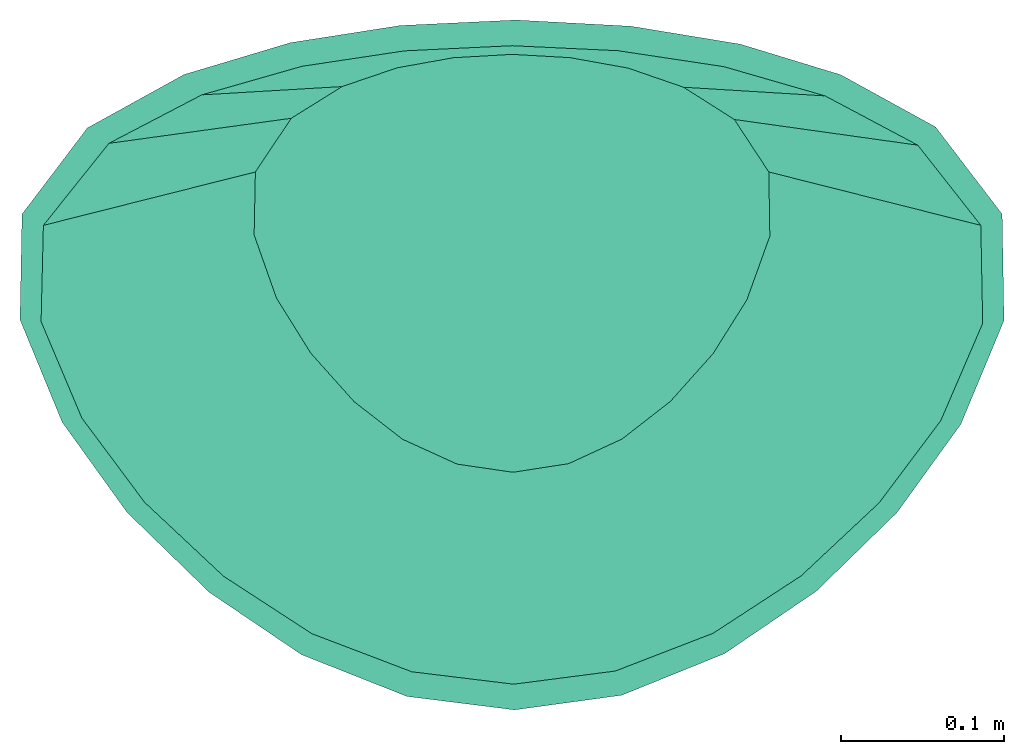
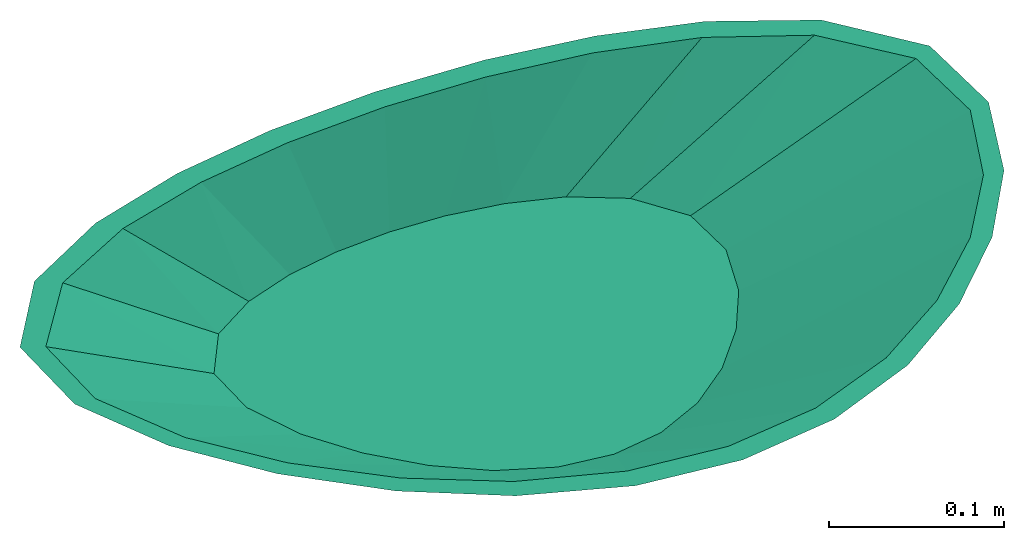
# Not in any storey: 1 sanitary terminal.
"""IFC4 building model written with IfcOpenShell, lengths in millimetres."""

from ifc_helpers import new_model, si_unit, direction, origin, place, context, subcontext, project, spatial, triangles, source, transform, mapped, material, type_object, type_shapes, element, save


model = new_model("IFC4")

# Units and contexts
model_context_1 = context("Model", 3, precision=0.0001, world=origin(), true_north=direction((0.0, 1.0)))
model_context_2 = context("Model", 3, precision=0.0001, world=origin(), true_north=direction((0.0, 1.0)))
body_context = subcontext(model_context_1, "Body", "Model", "MODEL_VIEW")
ifc_project = project(units=[si_unit("LENGTHUNIT", "METRE", prefix="MILLI"), si_unit("PLANEANGLEUNIT", "RADIAN"), si_unit("TIMEUNIT", "SECOND")], contexts=[model_context_2])

# Building
building_placement = place(None, origin())
building = spatial("IfcBuilding", under=ifc_project, at=building_placement, Name="IfcBuilding", CompositionType="ELEMENT")

# Sanitary terminal
ifc_material = material(Name="Ceramic")
sanitary_terminal_type = type_object("IfcSanitaryTerminalType", PredefinedType="WASHHANDBASIN", material=ifc_material)
shared_shape = source(origin(), body_context, "Body", "Tessellation", [
    triangles([(-300.0, 150.0, 0.0), (-260.012578, 202.771984, 0.0), (-200.897703, 235.427328, 0.0), (-135.653172, 254.960516, 0.0), (-68.351281, 265.485063, 0.0), (2.288734, 268.839531, 0.0), (72.81782, 265.023844, 0.0), (139.786906, 254.038063, 0.0), (201.174906, 235.317031, 0.0), (259.220938, 203.387031, 0.0), (300.0, 150.0, 0.0), (301.12175, 84.866148, 0.0), (274.727594, 21.433672, 0.0), (235.605922, -32.723826, 0.0), (186.088641, -80.939688, 0.0), (130.136258, -119.016594, 0.0), (67.084977, -144.523266, 0.0), (1.477218, -153.498641, 0.0), (-64.392137, -145.234375, 0.0), (-128.935, -119.668008, 0.0), (-185.4365, -81.474469, 0.0), (-235.751609, -32.555805, 0.0), (-275.439625, 22.660475, 0.0), (-301.2465, 85.400219, 0.0), (0.0, 253.099266, 0.0), (-65.777992, 249.952375, 0.0), (-128.508695, 240.511688, 0.0), (-189.983266, 222.998141, 0.0), (-246.840234, 193.330969, 0.0), (-286.93375, 143.116359, 0.0), (-288.338563, 84.231891, 0.0), (-263.388344, 25.178932, 0.0), (-224.986906, -26.382564, 0.0), (-176.642109, -71.667547, 0.0), (-122.550633, -106.846461, 0.0), (-61.391031, -130.155953, 0.0), (1.00923, -137.756953, 0.0), (63.202145, -129.69757, 0.0), (123.138398, -106.540977, 0.0), (176.955734, -71.42018, 0.0), (224.650078, -26.756678, 0.0), (262.387781, 23.516443, 0.0), (288.070906, 83.103938, 0.0), (286.93375, 143.116359, 0.0), (248.344641, 192.212875, 0.0), (191.622094, 222.376281, 0.0), (129.659992, 240.269531, 0.0), (64.742059, 250.052203, 0.0), (-157.154922, 175.808609, -94.0), (-136.207516, 207.772813, -94.0), (-105.240203, 227.552281, -94.0), (-71.061875, 239.383609, -94.0), (-35.805801, 245.758375, -94.0), (1.198953, 247.790172, -94.0), (38.145594, 245.479016, -94.0), (73.227336, 238.824875, -94.0), (105.385414, 227.485469, -94.0), (135.792813, 208.145344, -94.0), (157.154922, 175.808609, -94.0), (157.742547, 136.356797, -94.0), (143.915969, 97.9355, -94.0), (123.422102, 65.13209, -94.0), (97.482477, 35.927559, -94.0), (68.171844, 12.864227, -94.0), (35.142449, -2.585266, -94.0), (0.77384, -8.021682, -94.0), (-33.731801, -3.015985, -94.0), (-67.542563, 12.469661, -94.0), (-97.140859, 35.603637, -94.0), (-123.498414, 65.233859, -94.0), (-144.288969, 98.678578, -94.0), (-157.807906, 136.680281, -94.0), (-300.0, 150.0, 0.0), (-228.577453, 162.904313, -47.0), (-157.154922, 175.808609, -94.0), (-260.012578, 202.771984, 0.0), (-136.207516, 207.772813, -94.0), (-200.897703, 235.427328, 0.0), (-105.240203, 227.552281, -94.0), (-135.653172, 254.960516, 0.0), (-71.061875, 239.383609, -94.0), (-68.351281, 265.485063, 0.0), (-35.805801, 245.758375, -94.0), (2.288734, 268.839531, 0.0), (1.198953, 247.790172, -94.0), (72.81782, 265.023844, 0.0), (38.145594, 245.479016, -94.0), (139.786906, 254.038063, 0.0), (73.227336, 238.824875, -94.0), (201.174906, 235.317031, 0.0), (105.385414, 227.485469, -94.0), (259.220938, 203.387031, 0.0), (135.792813, 208.145344, -94.0), (300.0, 150.0, 0.0), (157.154922, 175.808609, -94.0), (301.12175, 84.866148, 0.0), (157.742547, 136.356797, -94.0), (274.727594, 21.433672, 0.0), (143.915969, 97.9355, -94.0), (235.605922, -32.723826, 0.0), (123.422102, 65.13209, -94.0), (186.088641, -80.939688, 0.0), (97.482477, 35.927559, -94.0), (130.136258, -119.016594, 0.0), (68.171844, 12.864227, -94.0), (67.084977, -144.523266, 0.0), (35.142449, -2.585266, -94.0), (1.477218, -153.498641, 0.0), (0.77384, -8.021682, -94.0), (-64.392137, -145.234375, 0.0), (-33.731801, -3.015985, -94.0), (-128.935, -119.668008, 0.0), (-67.542563, 12.469661, -94.0), (-185.4365, -81.474469, 0.0), (-97.140859, 35.603637, -94.0), (-235.751609, -32.555805, 0.0), (-123.498414, 65.233859, -94.0), (-275.439625, 22.660475, 0.0), (-144.288969, 98.678578, -94.0), (-301.2465, 85.400219, 0.0), (-157.807906, 136.680281, -94.0), (-300.0, 150.0, 0.0), (-228.577453, 162.904313, -47.0), (-157.154922, 175.808609, -94.0), (-103.357523, 247.172063, -47.0), (-153.068953, 231.489813, -47.0), (-52.078543, 255.621719, -47.0), (1.743843, 258.314844, -47.0), (55.481707, 255.251438, -47.0), (106.507117, 246.431469, -47.0), (197.506875, 205.766188, -47.0), (153.280156, 231.40125, -47.0), (228.577453, 162.904313, -47.0), (229.432141, 110.611469, -47.0), (209.321781, 59.684586, -47.0), (179.514016, 16.204132, -47.0), (141.785563, -22.506064, -47.0), (51.113715, -73.554266, -47.0), (99.154047, -53.076184, -47.0), (1.125529, -80.760164, -47.0), (-49.061969, -74.12518, -47.0), (-98.238781, -53.599176, -47.0), (-141.288688, -22.935416, -47.0), (-209.864297, 60.669523, -47.0), (-179.625016, 16.339027, -47.0), (-229.527203, 111.04025, -47.0), (0.0, 247.792422, -84.0), (35.45952, 245.798125, -84.0), (71.015367, 239.395359, -84.0), (104.952289, 227.684234, -84.0), (136.019484, 207.942281, -84.0), (157.154922, 175.808609, -84.0), (157.77775, 136.530484, -84.0), (143.710984, 97.530469, -84.0), (123.041867, 64.626715, -84.0), (96.919461, 35.394453, -84.0), (67.443461, 12.407895, -84.0), (34.616102, -2.748099, -84.0), (0.55276, -8.022964, -84.0), (-33.624148, -3.048111, -84.0), (-67.121539, 12.207951, -84.0), (-96.747688, 35.232555, -84.0), (-123.226352, 64.87157, -84.0), (-144.259, 98.61857, -84.0), (-157.924344, 137.268734, -84.0), (-157.154922, 175.808609, -84.0), (-135.195516, 208.674078, -84.0), (-104.054703, 228.091234, -84.0), (-70.384797, 239.553859, -84.0), (-36.026906, 245.732781, -84.0), (0.0, 247.792422, -84.0), (0.0, 253.099266, 0.0), (64.742059, 250.052203, 0.0), (129.659992, 240.269531, 0.0), (191.622094, 222.376281, 0.0), (248.344641, 192.212875, 0.0), (286.93375, 143.116359, 0.0), (288.070906, 83.103938, 0.0), (262.387781, 23.516443, 0.0), (224.650078, -26.756678, 0.0), (176.955734, -71.42018, 0.0), (123.138398, -106.540977, 0.0), (63.202145, -129.69757, 0.0), (1.00923, -137.756953, 0.0), (-61.391031, -130.155953, 0.0), (-122.550633, -106.846461, 0.0), (-176.642109, -71.667547, 0.0), (-224.986906, -26.382564, 0.0), (-263.388344, 25.178932, 0.0), (-288.338563, 84.231891, 0.0), (-286.93375, 143.116359, 0.0), (-246.840234, 193.330969, 0.0), (-189.983266, 222.998141, 0.0), (-128.508695, 240.511688, 0.0), (-65.777992, 249.952375, 0.0), (0.0, 253.099266, 0.0), (0.0, 247.792422, -84.0), (35.45952, 245.798125, -84.0), (71.015367, 239.395359, -84.0), (104.952289, 227.684234, -84.0), (136.019484, 207.942281, -84.0), (157.154922, 175.808609, -84.0), (157.77775, 136.530484, -84.0), (143.710984, 97.530469, -84.0), (123.041867, 64.626715, -84.0), (96.919461, 35.394453, -84.0), (67.443461, 12.407895, -84.0), (34.616102, -2.748099, -84.0), (0.55276, -8.022964, -84.0), (-33.624148, -3.048111, -84.0), (-67.121539, 12.207951, -84.0), (-96.747688, 35.232555, -84.0), (-123.226352, 64.87157, -84.0), (-144.259, 98.61857, -84.0), (-157.924344, 137.268734, -84.0), (-157.154922, 175.808609, -84.0), (-135.195516, 208.674078, -84.0), (-104.054703, 228.091234, -84.0), (-70.384797, 239.553859, -84.0), (-36.026906, 245.732781, -84.0)], [[28, 2, 29], [1, 29, 2], [30, 1, 24], [29, 1, 30], [24, 31, 30], [3, 2, 28], [5, 4, 27], [6, 5, 25], [25, 5, 26], [4, 28, 27], [5, 27, 26], [3, 28, 4], [23, 32, 31], [33, 32, 23], [24, 23, 31], [34, 22, 21], [23, 22, 33], [22, 34, 33], [21, 20, 35], [36, 35, 20], [34, 21, 35], [37, 36, 19], [20, 19, 36], [18, 37, 19], [7, 6, 48], [8, 7, 47], [7, 48, 47], [8, 47, 46], [46, 9, 8], [46, 45, 10], [11, 10, 45], [12, 11, 44], [45, 44, 11], [10, 9, 46], [12, 44, 43], [15, 39, 16], [40, 39, 15], [38, 16, 39], [18, 17, 37], [16, 38, 17], [17, 38, 37], [13, 43, 42], [12, 43, 13], [14, 13, 42], [15, 14, 40], [14, 41, 40], [42, 41, 14], [48, 6, 25], [50, 72, 49], [51, 72, 50], [71, 72, 52], [51, 52, 72], [53, 71, 52], [69, 70, 63], [71, 54, 70], [66, 67, 65], [67, 68, 65], [68, 69, 64], [71, 53, 54], [54, 55, 61], [55, 56, 61], [58, 60, 57], [60, 56, 57], [59, 60, 58], [65, 68, 64], [69, 63, 64], [62, 63, 70], [62, 54, 61], [61, 56, 60], [62, 70, 54], [74, 73, 76], [80, 125, 126], [126, 76, 78], [126, 77, 76], [76, 77, 74], [82, 127, 125], [127, 82, 84], [127, 83, 81], [125, 81, 79], [128, 84, 129], [88, 130, 86], [92, 131, 90], [90, 132, 88], [94, 133, 92], [96, 134, 94], [98, 135, 96], [128, 85, 83], [77, 75, 74], [77, 126, 79], [85, 128, 87], [87, 129, 89], [131, 93, 132], [134, 97, 133], [97, 134, 99], [133, 95, 131], [132, 91, 130], [135, 98, 136], [102, 137, 100], [106, 138, 104], [104, 139, 102], [137, 103, 136], [108, 140, 106], [138, 107, 139], [139, 105, 137], [99, 135, 101], [141, 110, 112], [114, 143, 142], [141, 111, 109], [110, 141, 140], [118, 144, 145], [120, 146, 144], [116, 145, 143], [122, 123, 146], [140, 109, 138], [111, 141, 142], [113, 142, 143], [145, 117, 115], [146, 121, 119], [123, 124, 121], [144, 119, 117], [148, 173, 172], [149, 174, 173], [151, 176, 175], [152, 177, 176], [150, 175, 174], [154, 179, 178], [155, 180, 179], [157, 182, 181], [158, 183, 182], [156, 181, 180], [153, 178, 177], [160, 185, 159], [161, 186, 160], [163, 188, 162], [164, 189, 163], [162, 187, 161], [166, 191, 165], [167, 192, 166], [169, 194, 168], [171, 196, 170], [170, 195, 169], [168, 193, 167], [165, 190, 164], [159, 184, 183], [217, 216, 215], [217, 215, 218], [220, 219, 214], [215, 219, 218], [197, 220, 214], [214, 213, 197], [219, 215, 214], [210, 208, 211], [213, 212, 205], [212, 211, 207], [197, 213, 205], [198, 204, 199], [200, 199, 203], [203, 202, 201], [200, 203, 201], [203, 199, 204], [209, 208, 210], [208, 207, 211], [206, 212, 207], [212, 206, 205], [197, 205, 204], [197, 204, 198], [80, 126, 78], [82, 125, 80], [127, 84, 128], [127, 81, 125], [125, 79, 126], [84, 86, 129], [130, 129, 86], [131, 132, 90], [132, 130, 88], [133, 131, 92], [134, 133, 94], [135, 134, 96], [128, 83, 127], [128, 129, 87], [129, 130, 89], [93, 91, 132], [97, 95, 133], [134, 135, 99], [95, 93, 131], [91, 89, 130], [98, 100, 136], [137, 136, 100], [138, 139, 104], [139, 137, 102], [103, 101, 136], [140, 138, 106], [107, 105, 139], [105, 103, 137], [135, 136, 101], [141, 112, 142], [114, 142, 112], [141, 109, 140], [110, 140, 108], [118, 145, 116], [120, 144, 118], [116, 143, 114], [122, 146, 120], [109, 107, 138], [111, 142, 113], [113, 143, 115], [145, 115, 143], [146, 119, 144], [123, 121, 146], [144, 117, 145], [148, 172, 147], [149, 173, 148], [151, 175, 150], [152, 176, 151], [150, 174, 149], [154, 178, 153], [155, 179, 154], [157, 181, 156], [158, 182, 157], [156, 180, 155], [153, 177, 152], [185, 184, 159], [186, 185, 160], [188, 187, 162], [189, 188, 163], [187, 186, 161], [191, 190, 165], [192, 191, 166], [194, 193, 168], [196, 195, 170], [195, 194, 169], [193, 192, 167], [190, 189, 164], [159, 183, 158]], closed=True),
])
type_shapes(sanitary_terminal_type, [shared_shape])
sanitary_terminal_placement = place(building_placement, origin())
element("IfcSanitaryTerminal", 1, at=sanitary_terminal_placement, inside=building, type_object=sanitary_terminal_type, PredefinedType="NOTDEFINED", context=body_context, shape_type="MappedRepresentation", body=[
    mapped(shared_shape, transform((0.0, 0.0, 0.0), x_axis=(1.0, 0.0, 0.0), y_axis=(0.0, 1.0, 0.0), z_axis=(0.0, 0.0, 1.0), scale=1.0)),
])

save(model, "model.ifc")
